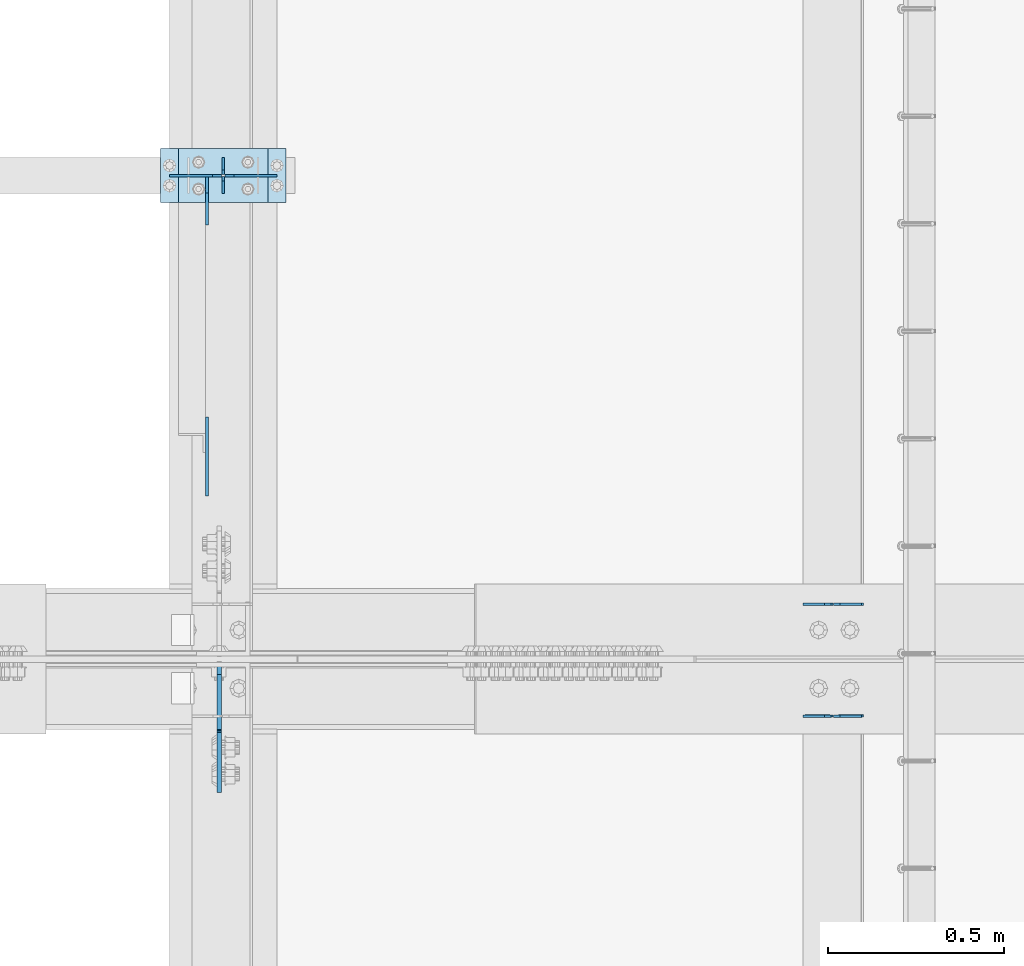
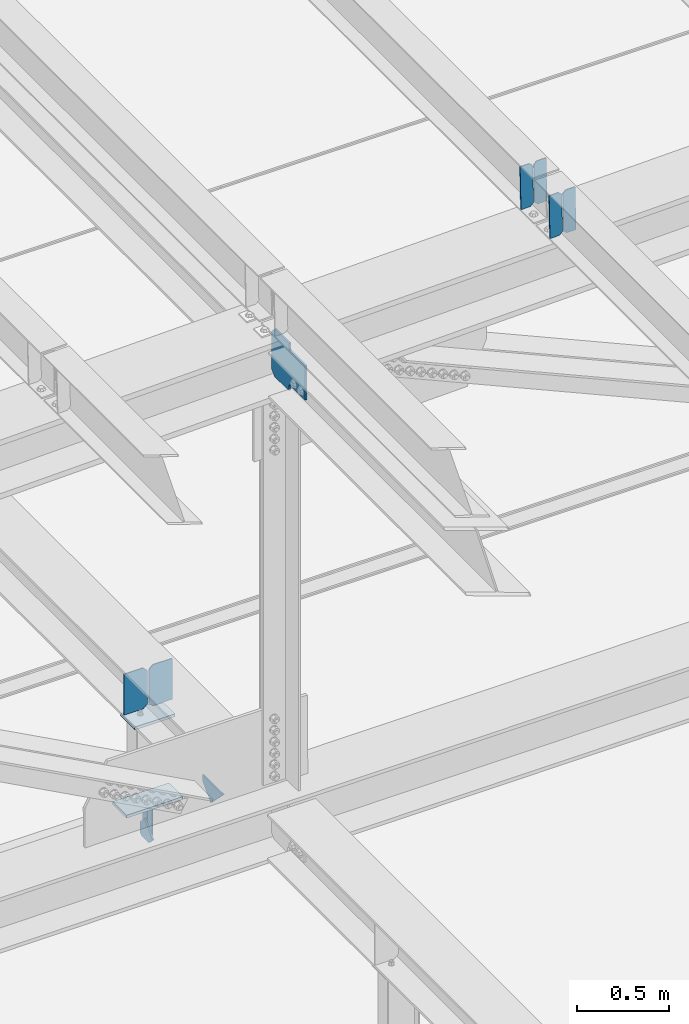
# One storey, part 3240 of 3843: 13 plates, 6 elements without a shape of their own.
"""IFC2X3 building model written with IfcOpenShell, lengths in millimetres."""

from ifc_helpers import new_model, si_unit, frame, origin_with_axes, place, context, subcontext, project, spatial, faceted_brep, material, type_object, element, aggregate, save


model = new_model("IFC2X3")

# Units and contexts
model_context = context("Model", 3, precision=1e-05, world=origin_with_axes())
body_context = subcontext(model_context, "Body", "Model", "MODEL_VIEW")
ifc_project = project(units=[si_unit("LENGTHUNIT", "METRE", prefix="MILLI"), si_unit("AREAUNIT", "SQUARE_METRE"), si_unit("VOLUMEUNIT", "CUBIC_METRE"), si_unit("MASSUNIT", "GRAM", prefix="KILO"), si_unit("TIMEUNIT", "SECOND"), si_unit("PLANEANGLEUNIT", "RADIAN"), si_unit("SOLIDANGLEUNIT", "STERADIAN"), si_unit("THERMODYNAMICTEMPERATUREUNIT", "DEGREE_CELSIUS"), si_unit("LUMINOUSINTENSITYUNIT", "LUMEN")], contexts=[model_context])

# Site, building, storey
site_placement = place(None, origin_with_axes())
site = spatial("IfcSite", under=ifc_project, at=site_placement, CompositionType="ELEMENT")
building_placement = place(site_placement, origin_with_axes())
building = spatial("IfcBuilding", under=site, at=building_placement, Name="Undefined", CompositionType="ELEMENT")
storey_placement = place(building_placement, origin_with_axes())
storey = spatial("IfcBuildingStorey", under=building, at=storey_placement, Name="Undefined", CompositionType="ELEMENT", Elevation=0.0)

# Assembly, plates
assembly_1_placement = place(storey_placement, origin_with_axes())
assembly_1 = element("IfcElementAssembly", 1, at=assembly_1_placement, inside=storey, Name="BEAM", AssemblyPlace="NOTDEFINED", PredefinedType="RIGID_FRAME")
ifc_material = material(Name="STEEL/A572-50")
plate_type_1 = type_object("IfcPlateType", PredefinedType="NOTDEFINED")
plate_1_placement = place(assembly_1_placement, frame((43878.2464782865, 42357.8812490567, 45617.4323529464), z_axis=(-0.021152098069586, -0.00069168800004991, 0.999776030076219), x_axis=(-0.99977626935017, 1.43409999980804e-05, -0.021152093007374)))
plate_1 = element("IfcPlate", 2, at=plate_1_placement, type_object=plate_type_1, material=ifc_material, Name="PLATE", context=body_context, shape_type="Brep", body=[
    faceted_brep([(0.0, -3.17499999999927, 0.0), (6.83940015733242e-10, -3.17499999996653, 288.924999998613), (6.54836185276508e-10, 3.17500000001746, 288.924999998591), (0.0, 3.17499999999927, 0.0), (60.3250007643655, -3.17500000017753, 288.924999998606), (60.3250007643219, 3.17499999979918, 288.924999998584), (79.3750000013097, -3.17500000025029, 269.875000761494), (79.375000001266, 3.17499999972642, 269.875000761487), (79.375000000713, -3.17500000026484, 19.0499992370605), (79.3750000006985, 3.17499999971187, 19.0499992370533), (60.325000763667, -3.17500000020664, -1.45519152283669e-11), (60.3250007636234, 3.17499999977736, -3.63797880709171e-11)], [[[0, 1, 2, 3]], [[1, 4, 5, 2]], [[4, 6, 7, 5]], [[6, 8, 9, 7]], [[8, 10, 11, 9]], [[10, 0, 3, 11]], [[5, 7, 9, 11, 3, 2]], [[10, 8, 6, 4, 1, 0]]]),
])
plate_2_placement = place(assembly_1_placement, frame((43792.5406575969, 42357.8825035491, 45615.6190897796), z_axis=(-0.021152098069586, -0.00069168800004991, 0.999776030076219), x_axis=(-0.99977626935017, 1.43409999980804e-05, -0.021152093007374)))
plate_2 = element("IfcPlate", 3, at=plate_2_placement, type_object=plate_type_1, material=ifc_material, Name="PLATE", context=body_context, shape_type="Brep", body=[
    faceted_brep([(4.36557456851006e-11, -3.17499999998836, 19.0499992370969), (6.11180439591408e-10, -3.17499999996653, 269.875000761516), (5.96628524363041e-10, 3.17500000001746, 269.875000761502), (1.45519152283669e-11, 3.17499999998836, 19.0499992370824), (19.0499992376572, -3.17500000003201, 288.924999998606), (19.0499992376281, 3.1749999999447, 288.924999998584), (79.3750000013242, -3.17500000025029, 288.924999998591), (79.3750000013097, 3.1749999997337, 288.92499999857), (79.3750000006548, -3.17500000026484, -2.18278728425503e-11), (79.3750000006403, 3.17499999969732, -2.91038304567337e-11), (19.0499992370023, -3.17500000005384, 0.0), (19.0499992369587, 3.17499999992287, -1.45519152283669e-11)], [[[0, 1, 2, 3]], [[1, 4, 5, 2]], [[4, 6, 7, 5]], [[6, 8, 9, 7]], [[8, 10, 11, 9]], [[10, 0, 3, 11]], [[5, 7, 9, 11, 3, 2]], [[10, 8, 6, 4, 1, 0]]]),
])
aggregate(assembly_1, [plate_1, plate_2])

assembly_2_placement = place(storey_placement, origin_with_axes())
assembly_2 = element("IfcElementAssembly", 4, at=assembly_2_placement, inside=storey, Name="BEAM", AssemblyPlace="NOTDEFINED", PredefinedType="RIGID_FRAME")
plate_3_placement = place(assembly_2_placement, frame((43878.2464782649, 42041.2426082677, 45616.7498989697), z_axis=(-0.0211520980270507, -0.00357224400155975, 0.999769887435027), x_axis=(-0.999776269346825, 7.55769999954079e-05, -0.021151963007321)))
plate_3 = element("IfcPlate", 5, at=plate_3_placement, type_object=plate_type_1, material=ifc_material, Name="PLATE", context=body_context, shape_type="Brep", body=[
    faceted_brep([(0.0, -3.17499999999927, 0.0), (6.83940015733242e-10, -3.17499999996653, 288.924999998613), (6.54836185276508e-10, 3.17500000001746, 288.924999998591), (0.0, 3.17499999999927, 0.0), (60.3250007643655, -3.17500000017753, 288.924999998606), (60.3250007643219, 3.17499999979918, 288.924999998584), (79.3750000013097, -3.17500000025029, 269.875000761494), (79.375000001266, 3.17499999972642, 269.875000761487), (79.375000000713, -3.17500000026484, 19.0499992370605), (79.3750000006985, 3.17499999971187, 19.0499992370533), (60.325000763667, -3.17500000020664, -1.45519152283669e-11), (60.3250007636234, 3.17499999977736, -3.63797880709171e-11)], [[[0, 1, 2, 3]], [[1, 4, 5, 2]], [[4, 6, 7, 5]], [[6, 8, 9, 7]], [[8, 10, 11, 9]], [[10, 0, 3, 11]], [[5, 7, 9, 11, 3, 2]], [[10, 8, 6, 4, 1, 0]]]),
])
plate_4_placement = place(assembly_2_placement, frame((43792.5406575752, 42041.2490871367, 45614.9366469425), z_axis=(-0.0211520980270507, -0.00357224400155975, 0.999769887435027), x_axis=(-0.999776269346825, 7.55769999954079e-05, -0.021151963007321)))
plate_4 = element("IfcPlate", 6, at=plate_4_placement, type_object=plate_type_1, material=ifc_material, Name="PLATE", context=body_context, shape_type="Brep", body=[
    faceted_brep([(4.36557456851006e-11, -3.17499999998836, 19.0499992370969), (6.11180439591408e-10, -3.17499999996653, 269.875000761516), (5.96628524363041e-10, 3.17500000001746, 269.875000761502), (1.45519152283669e-11, 3.17499999998836, 19.0499992370824), (19.0499992376572, -3.17500000003201, 288.924999998606), (19.0499992376281, 3.1749999999447, 288.924999998584), (79.3750000013242, -3.17500000025029, 288.924999998591), (79.3750000013097, 3.1749999997337, 288.92499999857), (79.3750000006548, -3.17500000026484, -2.18278728425503e-11), (79.3750000006403, 3.17499999969732, -2.91038304567337e-11), (19.0499992370023, -3.17500000005384, 0.0), (19.0499992369587, 3.17499999992287, -1.45519152283669e-11)], [[[0, 1, 2, 3]], [[1, 4, 5, 2]], [[4, 6, 7, 5]], [[6, 8, 9, 7]], [[8, 10, 11, 9]], [[10, 0, 3, 11]], [[5, 7, 9, 11, 3, 2]], [[10, 8, 6, 4, 1, 0]]]),
])
aggregate(assembly_2, [plate_3, plate_4])

assembly_3_placement = place(storey_placement, origin_with_axes())
assembly_3 = element("IfcElementAssembly", 7, at=assembly_3_placement, inside=storey, Name="BEAM", AssemblyPlace="NOTDEFINED", PredefinedType="RIGID_FRAME")
plate_type_2 = type_object("IfcPlateType", PredefinedType="NOTDEFINED")
plate_5_placement = place(assembly_3_placement, frame((42062.4, 43522.9, 41495.6625), z_axis=(0.0, 0.0, -1.0), x_axis=(0.0, 1.0, 0.0)))
plate_5 = element("IfcPlate", 8, at=plate_5_placement, type_object=plate_type_2, material=ifc_material, Name="PLATE", context=body_context, shape_type="Brep", body=[
    faceted_brep([(0.0, -3.17499999999927, 0.0), (0.0, -3.17500000000291, 187.324999999997), (0.0, 3.17500000000291, 187.324999999997), (0.0, 3.17499999999927, 0.0), (34.9250001907349, -3.17500000000291, 187.324999999997), (34.9250001907349, 3.17500000000291, 187.324999999997), (47.625, -3.17500000000291, 174.625000190732), (47.625, 3.17500000000291, 174.625000190732), (47.625, -3.17499999999927, 12.6999998092651), (47.625, 3.17499999999927, 12.6999998092651), (34.9250001907349, -3.17499999999927, 0.0), (34.9250001907349, 3.17499999999927, 0.0)], [[[0, 1, 2, 3]], [[1, 4, 5, 2]], [[4, 6, 7, 5]], [[6, 8, 9, 7]], [[8, 10, 11, 9]], [[10, 0, 3, 11]], [[5, 7, 9, 11, 3, 2]], [[10, 8, 6, 4, 1, 0]]]),
])
plate_6_placement = place(assembly_3_placement, frame((42062.4, 43624.5, 41495.6625), z_axis=(0.0, 0.0, -1.0), x_axis=(0.0, -1.0, 0.0)))
plate_6 = element("IfcPlate", 9, at=plate_6_placement, type_object=plate_type_2, material=ifc_material, Name="PLATE", context=body_context, shape_type="Brep", body=[
    faceted_brep([(0.0, -3.17499999999927, 0.0), (0.0, -3.17500000000291, 187.324999999997), (0.0, 3.17500000000291, 187.324999999997), (0.0, 3.17499999999927, 0.0), (34.9250001907349, -3.17500000000291, 187.324999999997), (34.9250001907349, 3.17500000000291, 187.324999999997), (47.625, -3.17500000000291, 174.625000190732), (47.625, 3.17500000000291, 174.625000190732), (47.625, -3.17499999999927, 12.6999998092651), (47.625, 3.17499999999927, 12.6999998092651), (34.9250001907349, -3.17499999999927, 0.0), (34.9250001907349, 3.17499999999927, 0.0)], [[[0, 1, 2, 3]], [[1, 4, 5, 2]], [[4, 6, 7, 5]], [[6, 8, 9, 7]], [[8, 10, 11, 9]], [[10, 0, 3, 11]], [[5, 7, 9, 11, 3, 2]], [[10, 8, 6, 4, 1, 0]]]),
])

# Assembly, plate
assembly_4_placement = place(storey_placement, origin_with_axes())
assembly_4 = element("IfcElementAssembly", 10, at=assembly_4_placement, inside=storey, Name="BEAM", AssemblyPlace="NOTDEFINED", PredefinedType="RIGID_FRAME")
plate_type_3 = type_object("IfcPlateType", PredefinedType="NOTDEFINED")
plate_7_placement = place(assembly_4_placement, frame((42051.2875706488, 42190.9874999872, 45236.4847905217), z_axis=(0.0, -0.707106781186682, 0.707106781186413), x_axis=(0.0, -0.707106781186548, -0.707106781186548)))
plate_7 = element("IfcPlate", 11, at=plate_7_placement, type_object=plate_type_3, material=ifc_material, Name="PLATE", context=body_context, shape_type="Brep", body=[
    faceted_brep([(0.0, -6.3499999046162, 0.0), (-179.450181359635, -6.34999999999854, 179.450181359643), (-179.450181359635, 6.34999999999854, 179.450181359643), (7.27595761418343e-12, 6.3499999046162, 0.0), (-179.450181359639, -6.34999999999854, 224.351461964776), (-179.450181359639, 6.34999999999854, 224.351461964776), (-68.3195118619651, -6.34999999999854, 335.482131462442), (-68.3195118619651, 6.34999999999854, 335.482131462442), (-45.6484022733421, -6.34999999999854, 312.81102192021), (-45.6484022733421, 6.34999999999854, 312.81102192021), (-41.5282258052102, -6.34999999999854, 310.058008019744), (-41.5282258052102, 6.34999999999854, 310.058008019744), (-36.6681462871711, -6.34999999999854, 309.091278097156), (-36.6681462871711, 6.34999999999854, 309.091278097156), (-31.808066769132, -6.34999999999854, 310.058008019736), (-31.808066769132, 6.34999999999854, 310.058008019736), (-27.6878903009856, -6.34999999999854, 312.81102192021), (-27.6878903009856, 6.34999999999854, 312.81102192021), (89.0554393840212, -6.34999999999854, 429.554351605217), (89.0554393840212, 6.34999999999854, 429.554351605217), (250.700049562489, -6.34999999999854, 267.909741426746), (250.700049562489, 6.34999999999854, 267.909741426746), (133.956719877482, -6.34999999999854, 151.166411741739), (133.956719877482, 6.34999999999854, 151.166411741739), (131.203705977008, -6.34999999999854, 147.046235273593), (131.203705977008, 6.34999999999854, 147.046235273593), (130.236976054424, -6.34999999999854, 142.186155755561), (130.236976054424, 6.34999999999854, 142.186155755561), (131.203705977008, -6.34999999999854, 137.326076237529), (131.203705977008, 6.34999999999854, 137.326076237529), (133.956719877482, -6.34999999999854, 133.205899769383), (133.956719877482, 6.34999999999854, 133.205899769383), (156.031950102829, -6.35000000000582, 111.130669497703), (156.031950102829, 6.35000000000582, 111.130669497703), (44.9012806051323, -6.35000000000582, -1.45519152283669e-11), (44.9012806051323, 6.35000000000582, -1.45519152283669e-11)], [[[0, 1, 2, 3]], [[1, 4, 5, 2]], [[4, 6, 7, 5]], [[6, 8, 9, 7]], [[8, 10, 11, 9]], [[10, 12, 13, 11]], [[12, 14, 15, 13]], [[14, 16, 17, 15]], [[16, 18, 19, 17]], [[18, 20, 21, 19]], [[20, 22, 23, 21]], [[22, 24, 25, 23]], [[24, 26, 27, 25]], [[26, 28, 29, 27]], [[28, 30, 31, 29]], [[30, 32, 33, 31]], [[32, 34, 35, 33]], [[34, 0, 3, 35]], [[5, 7, 9, 11, 13, 15, 17, 19, 21, 23, 25, 27, 29, 31, 33, 35, 3, 2]], [[34, 32, 30, 28, 26, 24, 22, 20, 18, 16, 14, 12, 10, 8, 6, 4, 1, 0]]]),
])
aggregate(assembly_4, [plate_7])

# Assembly, plates
assembly_5_placement = place(storey_placement, origin_with_axes())
assembly_5 = element("IfcElementAssembly", 12, at=assembly_5_placement, inside=storey, Name="POST", AssemblyPlace="NOTDEFINED", PredefinedType="RIGID_FRAME")
plate_type_4 = type_object("IfcPlateType", PredefinedType="NOTDEFINED")
plate_8_placement = place(assembly_5_placement, frame((41935.399996921, 43649.9050939797, 42083.0375013681), z_axis=(0.0, -0.999999856378788, -0.00053595000020141), x_axis=(1.0, 0.0, 0.0)))
plate_8 = element("IfcPlate", 13, at=plate_8_placement, type_object=plate_type_4, material=ifc_material, Name="PLATE", context=body_context, shape_type="Brep", body=[
    faceted_brep([(0.0, -9.52500000000146, 0.0), (0.0, -9.5249999999287, 152.40000000162), (0.0, 9.52500000002328, 152.40000000162), (0.0, 9.52500000000146, 0.0), (254.0, -9.5249999999287, 152.40000000162), (254.0, 9.52500000002328, 152.40000000162), (253.999999999998, -9.52500000000146, 0.0), (253.999999999998, 9.52500000000146, 0.0)], [[[0, 1, 2, 3]], [[1, 4, 5, 2]], [[4, 6, 7, 5]], [[6, 0, 3, 7]], [[5, 7, 3, 2]], [[6, 4, 1, 0]]]),
])
plate_9_placement = place(assembly_5_placement, frame((42240.2, 43497.5, 41513.125), z_axis=(-1.0, 0.0, 0.0), x_axis=(0.0, 1.0, 0.0)))
plate_9 = element("IfcPlate", 14, at=plate_9_placement, type_object=plate_type_4, material=ifc_material, Name="PLATE", context=body_context, shape_type="Brep", body=[
    faceted_brep([(0.0, -9.52500000000146, 0.0), (0.0, -9.52500000000146, 355.599999999999), (0.0, 9.52500000000146, 355.599999999999), (0.0, 9.52500000000146, 0.0), (152.399999999994, -9.52500000000146, 355.599999999999), (152.399999999994, 9.52500000000146, 355.599999999999), (152.400000000001, -9.52500000000146, 0.0), (152.400000000001, 9.52500000000146, 0.0)], [[[0, 1, 2, 3]], [[1, 4, 5, 2]], [[4, 6, 7, 5]], [[6, 0, 3, 7]], [[5, 7, 3, 2]], [[6, 4, 1, 0]]]),
])
aggregate(assembly_5, [plate_8, plate_9])

# Assembly, plate
assembly_6_placement = place(storey_placement, origin_with_axes())
assembly_6 = element("IfcElementAssembly", 15, at=assembly_6_placement, inside=storey, Name="BEAM", AssemblyPlace="NOTDEFINED", PredefinedType="RIGID_FRAME")
plate_type_5 = type_object("IfcPlateType", PredefinedType="NOTDEFINED")
plate_10_placement = place(assembly_6_placement, frame((42016.3625, 42665.2329714052, 42118.9710060284), z_axis=(0.0, 0.707106781186548, 0.707106781186548), x_axis=(5.70000238222118e-08, 0.707106781186546, -0.707106781186546)))
plate_10 = element("IfcPlate", 16, at=plate_10_placement, type_object=plate_type_5, material=ifc_material, Name="PLATE", context=body_context, shape_type="Brep", body=[
    faceted_brep([(0.0, -4.76249999999709, 0.0), (157.726597423803, -4.76249999999709, 157.726601438866), (157.726597423803, 4.76249999999709, 157.726601438866), (0.0, 4.76249999999709, 0.0), (188.387110059113, -4.76249999999709, 127.066089584019), (188.387110059113, 4.76249999999709, 127.066089584019), (188.387111679331, -4.76249999999709, 1.09139364212751e-10), (188.387111679331, 4.76249999999709, 1.09139364212751e-10)], [[[0, 1, 2, 3]], [[1, 4, 5, 2]], [[4, 6, 7, 5]], [[6, 0, 3, 7]], [[5, 7, 3, 2]], [[6, 4, 1, 0]]]),
])

# Plate
plate_type_6 = type_object("IfcPlateType", PredefinedType="NOTDEFINED")
plate_11_placement = place(assembly_3_placement, frame((42016.3625, 43570.5250000347, 41306.750000025), z_axis=(0.0, -1.0, 0.0), x_axis=(0.0, 0.0, 1.0)))
plate_11 = element("IfcPlate", 17, at=plate_11_placement, type_object=plate_type_6, material=ifc_material, Name="PLATE", context=body_context, shape_type="Brep", body=[
    faceted_brep([(0.0, -4.76250000000073, 12.6999998092651), (4.450703272596e-08, -4.76249999999709, 93.0710244828806), (4.450703272596e-08, 4.76249999999709, 93.0710244828806), (0.0, 4.76250000000073, 12.6999998092651), (43.3137807601452, -4.76249999999709, 136.384805065652), (43.3137807601452, 4.76249999999709, 136.384805065652), (133.209805202001, -4.76249999999709, 46.4887805392646), (133.209805202001, 4.76249999999709, 46.4887805392646), (86.7210245267561, -4.76249999999709, 0.0), (86.7210245267561, 4.76249999999709, 0.0), (12.6999998092651, -4.76250000000073, 0.0), (12.6999998092651, 4.76250000000073, 0.0)], [[[0, 1, 2, 3]], [[1, 4, 5, 2]], [[4, 6, 7, 5]], [[6, 8, 9, 7]], [[8, 10, 11, 9]], [[10, 0, 3, 11]], [[5, 7, 9, 11, 3, 2]], [[10, 8, 6, 4, 1, 0]]]),
])

aggregate(assembly_3, [plate_11, plate_5, plate_6])

plate_type_7 = type_object("IfcPlateType", PredefinedType="NOTDEFINED")
plate_12_placement = place(assembly_6_placement, frame((42214.8, 43573.5442998255, 42409.9221774997), z_axis=(0.0, 0.00053595000020141, -0.999999856378788), x_axis=(-1.0, 0.0, 0.0)))
plate_12 = element("IfcPlate", 18, at=plate_12_placement, type_object=plate_type_7, material=ifc_material, Name="PLATE", context=body_context, shape_type="Brep", body=[
    faceted_brep([(0.0, -3.17499999999927, 0.0), (0.0, -3.17500000007567, 273.049999997937), (0.0, 3.17499999993743, 273.049999997937), (0.0, 3.17499999999927, 0.0), (122.237500389827, -3.17500000007567, 273.049999997937), (122.237500389827, 3.17499999993743, 273.049999997937), (147.637500008357, -3.17500000006476, 247.650000379464), (147.637500008357, 3.17499999994106, 247.650000379464), (147.637500008357, -3.17500000001382, 25.3999996184648), (147.637500008357, 3.17499999999927, 25.3999996184648), (122.237500389827, -3.17500000000291, 0.0), (122.237500389827, 3.17500000000291, -7.27595761418343e-12)], [[[0, 1, 2, 3]], [[1, 4, 5, 2]], [[4, 6, 7, 5]], [[6, 8, 9, 7]], [[8, 10, 11, 9]], [[10, 0, 3, 11]], [[5, 7, 9, 11, 3, 2]], [[10, 8, 6, 4, 1, 0]]]),
])

plate_13_placement = place(assembly_6_placement, frame((41910.0, 43573.5442998255, 42409.9221774997), z_axis=(0.0, 0.00053595000020141, -0.999999856378788), x_axis=(1.0, 0.0, 0.0)))
plate_13 = element("IfcPlate", 19, at=plate_13_placement, type_object=plate_type_7, material=ifc_material, Name="PLATE", context=body_context, shape_type="Brep", body=[
    faceted_brep([(0.0, -3.17499999999927, 0.0), (0.0, -3.17500000007567, 273.049999997937), (0.0, 3.17499999993743, 273.049999997937), (0.0, 3.17499999999927, 0.0), (122.237500389827, -3.17500000007567, 273.049999997937), (122.237500389827, 3.17499999993743, 273.049999997937), (147.637500008357, -3.17500000006476, 247.650000379464), (147.637500008357, 3.17499999994106, 247.650000379464), (147.637500008357, -3.17500000001382, 25.3999996184648), (147.637500008357, 3.17499999999927, 25.3999996184648), (122.237500389827, -3.17500000000291, 0.0), (122.237500389827, 3.17500000000291, -7.27595761418343e-12)], [[[0, 1, 2, 3]], [[1, 4, 5, 2]], [[4, 6, 7, 5]], [[6, 8, 9, 7]], [[8, 10, 11, 9]], [[10, 0, 3, 11]], [[5, 7, 9, 11, 3, 2]], [[10, 8, 6, 4, 1, 0]]]),
])

aggregate(assembly_6, [plate_12, plate_13, plate_10])

save(model, "model.ifc")
